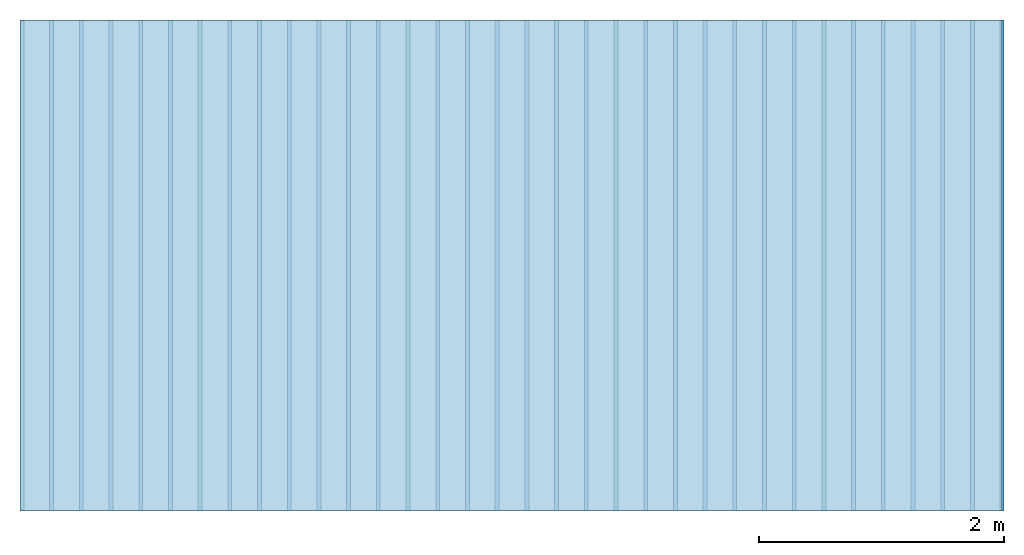
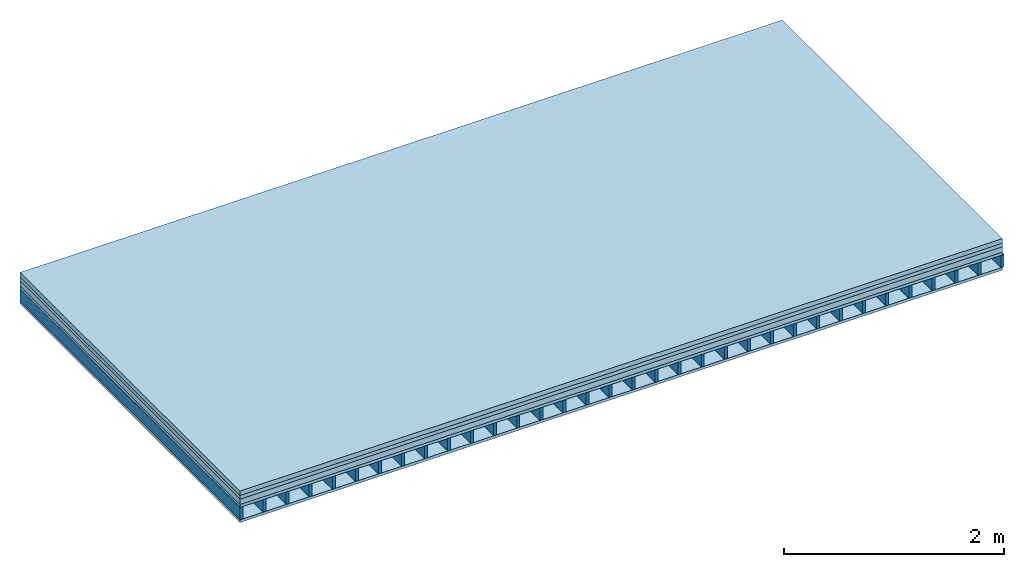
# One storey: 5 plates, 1 member, 1 element without a shape of its own.
"""IFC4 building model written with IfcOpenShell, lengths in metres."""

from ifc_helpers import new_model, si_unit, derived_unit, direction, frame, frame_2d, origin, origin_with_axes, place, context, project, spatial, rectangle, extrude, material, layer, layer_set, type_object, element, aggregate, save


model = new_model("IFC4")

# Units and contexts
plan_context = context("Plan", 3, precision=1e-05, world=origin(), true_north=direction((0.0, 1.0)))
model_context = context("Model", 3, precision=1e-05, world=origin(), true_north=direction((0.0, 1.0)))
ifc_project = project(units=[si_unit("LENGTHUNIT", "METRE"), derived_unit("SOUNDPRESSUREUNIT", [(si_unit("PRESSUREUNIT", "PASCAL", prefix="MICRO"), 0)]), si_unit("ENERGYUNIT", "JOULE", prefix="MEGA"), si_unit("MASSUNIT", "GRAM", prefix="KILO"), derived_unit("THERMALTRANSMITTANCEUNIT", [(si_unit("POWERUNIT", "WATT"), 1), (si_unit("AREAUNIT", "SQUARE_METRE"), -1), (si_unit("THERMODYNAMICTEMPERATUREUNIT", "KELVIN"), -1)]), derived_unit("AREADENSITYUNIT", [(si_unit("MASSUNIT", "GRAM", prefix="KILO"), 1), (si_unit("AREAUNIT", "SQUARE_METRE"), -1)]), derived_unit("USERDEFINED", [(si_unit("ENERGYUNIT", "JOULE", prefix="MEGA"), 1), (si_unit("AREAUNIT", "SQUARE_METRE"), -1)])], contexts=[plan_context, model_context])

# Site, building, storey
site = spatial("IfcSite", under=ifc_project)
building_placement = place(None, origin())
building = spatial("IfcBuilding", under=site, at=building_placement)
storey_placement = place(building_placement, origin())
storey = spatial("IfcBuildingStorey", under=building, at=storey_placement)

# Slab, member, plates
ifc_material_1 = material(Name="Cement screed", Category="04.006")
ifc_layer_1 = layer(ifc_material_1, 0.05, Name="On-material")
ifc_material_2 = material(Name="EP1, 40/35mm")
ifc_layer_2 = layer(ifc_material_2, 0.04, Name="Impact sound insulation")
ifc_material_3 = material(Category="03.011")
ifc_layer_3 = layer(ifc_material_3, 0.06, Name="on Supporting structure")
ifc_material_4 = material(Name="surface element sheathing above")
ifc_layer_4 = layer(ifc_material_4, 0.031, Name="Sub-floor")
ifc_layer_5 = layer(None, 0.138, Name="Supporting structure")
ifc_material_5 = material(Name="surface element sheathing below")
ifc_layer_6 = layer(ifc_material_5, 0.031, Name="Lower layer 1")
ifc_layer_set = layer_set([ifc_layer_1, ifc_layer_2, ifc_layer_3, ifc_layer_4, ifc_layer_5, ifc_layer_6])
slab_type = type_object("IfcSlabType", Name="A0082", PredefinedType="NOTDEFINED", material=ifc_layer_set)
slab_placement = place(None, frame((0.0, 0.0, 0.0), z_axis=(0.0, 0.0, -1.0), x_axis=(1.0, 0.0, 0.0)))
slab = element("IfcSlab", 1, at=slab_placement, inside=storey, type_object=slab_type, material=ifc_layer_set, Name="Slab #1")
ifc_material_6 = material(Name="surface element LFE")
member_placement = place(slab_placement, origin())
member = element("IfcMember", 2, at=member_placement, material=ifc_material_6, Name="Supporting structure", context=plan_context, shape_type="SweptSolid", body=[
    extrude(rectangle(XDim=0.031, YDim=0.138, at=frame_2d((0.0155, 0.069), x_axis=(1.0, 0.0))), frame((0.0, 4.0, 0.181), z_axis=(0.0, -1.0, 0.0), x_axis=(1.0, 0.0, 0.0)), (0.0, 0.0, 1.0), 4.0),
    extrude(rectangle(XDim=0.031, YDim=0.138, at=frame_2d((0.0155, 0.069), x_axis=(1.0, 0.0))), frame((0.242, 4.0, 0.181), z_axis=(0.0, -1.0, 0.0), x_axis=(1.0, 0.0, 0.0)), (0.0, 0.0, 1.0), 4.0),
    extrude(rectangle(XDim=0.031, YDim=0.138, at=frame_2d((0.0155, 0.069), x_axis=(1.0, 0.0))), frame((0.484, 4.0, 0.181), z_axis=(0.0, -1.0, 0.0), x_axis=(1.0, 0.0, 0.0)), (0.0, 0.0, 1.0), 4.0),
    extrude(rectangle(XDim=0.031, YDim=0.138, at=frame_2d((0.0155, 0.069), x_axis=(1.0, 0.0))), frame((0.726, 4.0, 0.181), z_axis=(0.0, -1.0, 0.0), x_axis=(1.0, 0.0, 0.0)), (0.0, 0.0, 1.0), 4.0),
    extrude(rectangle(XDim=0.031, YDim=0.138, at=frame_2d((0.0155, 0.069), x_axis=(1.0, 0.0))), frame((0.968, 4.0, 0.181), z_axis=(0.0, -1.0, 0.0), x_axis=(1.0, 0.0, 0.0)), (0.0, 0.0, 1.0), 4.0),
    extrude(rectangle(XDim=0.031, YDim=0.138, at=frame_2d((0.0155, 0.069), x_axis=(1.0, 0.0))), frame((1.21, 4.0, 0.181), z_axis=(0.0, -1.0, 0.0), x_axis=(1.0, 0.0, 0.0)), (0.0, 0.0, 1.0), 4.0),
    extrude(rectangle(XDim=0.031, YDim=0.138, at=frame_2d((0.0155, 0.069), x_axis=(1.0, 0.0))), frame((1.452, 4.0, 0.181), z_axis=(0.0, -1.0, 0.0), x_axis=(1.0, 0.0, 0.0)), (0.0, 0.0, 1.0), 4.0),
    extrude(rectangle(XDim=0.031, YDim=0.138, at=frame_2d((0.0155, 0.069), x_axis=(1.0, 0.0))), frame((1.694, 4.0, 0.181), z_axis=(0.0, -1.0, 0.0), x_axis=(1.0, 0.0, 0.0)), (0.0, 0.0, 1.0), 4.0),
    extrude(rectangle(XDim=0.031, YDim=0.138, at=frame_2d((0.0155, 0.069), x_axis=(1.0, 0.0))), frame((1.936, 4.0, 0.181), z_axis=(0.0, -1.0, 0.0), x_axis=(1.0, 0.0, 0.0)), (0.0, 0.0, 1.0), 4.0),
    extrude(rectangle(XDim=0.031, YDim=0.138, at=frame_2d((0.0155, 0.069), x_axis=(1.0, 0.0))), frame((2.178, 4.0, 0.181), z_axis=(0.0, -1.0, 0.0), x_axis=(1.0, 0.0, 0.0)), (0.0, 0.0, 1.0), 4.0),
    extrude(rectangle(XDim=0.031, YDim=0.138, at=frame_2d((0.0155, 0.069), x_axis=(1.0, 0.0))), frame((2.42, 4.0, 0.181), z_axis=(0.0, -1.0, 0.0), x_axis=(1.0, 0.0, 0.0)), (0.0, 0.0, 1.0), 4.0),
    extrude(rectangle(XDim=0.031, YDim=0.138, at=frame_2d((0.0155, 0.069), x_axis=(1.0, 0.0))), frame((2.662, 4.0, 0.181), z_axis=(0.0, -1.0, 0.0), x_axis=(1.0, 0.0, 0.0)), (0.0, 0.0, 1.0), 4.0),
    extrude(rectangle(XDim=0.031, YDim=0.138, at=frame_2d((0.0155, 0.069), x_axis=(1.0, 0.0))), frame((2.904, 4.0, 0.181), z_axis=(0.0, -1.0, 0.0), x_axis=(1.0, 0.0, 0.0)), (0.0, 0.0, 1.0), 4.0),
    extrude(rectangle(XDim=0.031, YDim=0.138, at=frame_2d((0.0155, 0.069), x_axis=(1.0, 0.0))), frame((3.146, 4.0, 0.181), z_axis=(0.0, -1.0, 0.0), x_axis=(1.0, 0.0, 0.0)), (0.0, 0.0, 1.0), 4.0),
    extrude(rectangle(XDim=0.031, YDim=0.138, at=frame_2d((0.0155, 0.069), x_axis=(1.0, 0.0))), frame((3.388, 4.0, 0.181), z_axis=(0.0, -1.0, 0.0), x_axis=(1.0, 0.0, 0.0)), (0.0, 0.0, 1.0), 4.0),
    extrude(rectangle(XDim=0.031, YDim=0.138, at=frame_2d((0.0155, 0.069), x_axis=(1.0, 0.0))), frame((3.63, 4.0, 0.181), z_axis=(0.0, -1.0, 0.0), x_axis=(1.0, 0.0, 0.0)), (0.0, 0.0, 1.0), 4.0),
    extrude(rectangle(XDim=0.031, YDim=0.138, at=frame_2d((0.0155, 0.069), x_axis=(1.0, 0.0))), frame((3.872, 4.0, 0.181), z_axis=(0.0, -1.0, 0.0), x_axis=(1.0, 0.0, 0.0)), (0.0, 0.0, 1.0), 4.0),
    extrude(rectangle(XDim=0.031, YDim=0.138, at=frame_2d((0.0155, 0.069), x_axis=(1.0, 0.0))), frame((4.114, 4.0, 0.181), z_axis=(0.0, -1.0, 0.0), x_axis=(1.0, 0.0, 0.0)), (0.0, 0.0, 1.0), 4.0),
    extrude(rectangle(XDim=0.031, YDim=0.138, at=frame_2d((0.0155, 0.069), x_axis=(1.0, 0.0))), frame((4.356, 4.0, 0.181), z_axis=(0.0, -1.0, 0.0), x_axis=(1.0, 0.0, 0.0)), (0.0, 0.0, 1.0), 4.0),
    extrude(rectangle(XDim=0.031, YDim=0.138, at=frame_2d((0.0155, 0.069), x_axis=(1.0, 0.0))), frame((4.598, 4.0, 0.181), z_axis=(0.0, -1.0, 0.0), x_axis=(1.0, 0.0, 0.0)), (0.0, 0.0, 1.0), 4.0),
    extrude(rectangle(XDim=0.031, YDim=0.138, at=frame_2d((0.0155, 0.069), x_axis=(1.0, 0.0))), frame((4.84, 4.0, 0.181), z_axis=(0.0, -1.0, 0.0), x_axis=(1.0, 0.0, 0.0)), (0.0, 0.0, 1.0), 4.0),
    extrude(rectangle(XDim=0.031, YDim=0.138, at=frame_2d((0.0155, 0.069), x_axis=(1.0, 0.0))), frame((5.082, 4.0, 0.181), z_axis=(0.0, -1.0, 0.0), x_axis=(1.0, 0.0, 0.0)), (0.0, 0.0, 1.0), 4.0),
    extrude(rectangle(XDim=0.031, YDim=0.138, at=frame_2d((0.0155, 0.069), x_axis=(1.0, 0.0))), frame((5.324, 4.0, 0.181), z_axis=(0.0, -1.0, 0.0), x_axis=(1.0, 0.0, 0.0)), (0.0, 0.0, 1.0), 4.0),
    extrude(rectangle(XDim=0.031, YDim=0.138, at=frame_2d((0.0155, 0.069), x_axis=(1.0, 0.0))), frame((5.566, 4.0, 0.181), z_axis=(0.0, -1.0, 0.0), x_axis=(1.0, 0.0, 0.0)), (0.0, 0.0, 1.0), 4.0),
    extrude(rectangle(XDim=0.031, YDim=0.138, at=frame_2d((0.0155, 0.069), x_axis=(1.0, 0.0))), frame((5.808, 4.0, 0.181), z_axis=(0.0, -1.0, 0.0), x_axis=(1.0, 0.0, 0.0)), (0.0, 0.0, 1.0), 4.0),
    extrude(rectangle(XDim=0.031, YDim=0.138, at=frame_2d((0.0155, 0.069), x_axis=(1.0, 0.0))), frame((6.05, 4.0, 0.181), z_axis=(0.0, -1.0, 0.0), x_axis=(1.0, 0.0, 0.0)), (0.0, 0.0, 1.0), 4.0),
    extrude(rectangle(XDim=0.031, YDim=0.138, at=frame_2d((0.0155, 0.069), x_axis=(1.0, 0.0))), frame((6.292, 4.0, 0.181), z_axis=(0.0, -1.0, 0.0), x_axis=(1.0, 0.0, 0.0)), (0.0, 0.0, 1.0), 4.0),
    extrude(rectangle(XDim=0.031, YDim=0.138, at=frame_2d((0.0155, 0.069), x_axis=(1.0, 0.0))), frame((6.534, 4.0, 0.181), z_axis=(0.0, -1.0, 0.0), x_axis=(1.0, 0.0, 0.0)), (0.0, 0.0, 1.0), 4.0),
    extrude(rectangle(XDim=0.031, YDim=0.138, at=frame_2d((0.0155, 0.069), x_axis=(1.0, 0.0))), frame((6.776, 4.0, 0.181), z_axis=(0.0, -1.0, 0.0), x_axis=(1.0, 0.0, 0.0)), (0.0, 0.0, 1.0), 4.0),
    extrude(rectangle(XDim=0.031, YDim=0.138, at=frame_2d((0.0155, 0.069), x_axis=(1.0, 0.0))), frame((7.018, 4.0, 0.181), z_axis=(0.0, -1.0, 0.0), x_axis=(1.0, 0.0, 0.0)), (0.0, 0.0, 1.0), 4.0),
    extrude(rectangle(XDim=0.031, YDim=0.138, at=frame_2d((0.0155, 0.069), x_axis=(1.0, 0.0))), frame((7.26, 4.0, 0.181), z_axis=(0.0, -1.0, 0.0), x_axis=(1.0, 0.0, 0.0)), (0.0, 0.0, 1.0), 4.0),
    extrude(rectangle(XDim=0.031, YDim=0.138, at=frame_2d((0.0155, 0.069), x_axis=(1.0, 0.0))), frame((7.502, 4.0, 0.181), z_axis=(0.0, -1.0, 0.0), x_axis=(1.0, 0.0, 0.0)), (0.0, 0.0, 1.0), 4.0),
    extrude(rectangle(XDim=0.031, YDim=0.138, at=frame_2d((0.0155, 0.069), x_axis=(1.0, 0.0))), frame((7.744, 4.0, 0.181), z_axis=(0.0, -1.0, 0.0), x_axis=(1.0, 0.0, 0.0)), (0.0, 0.0, 1.0), 4.0),
    extrude(rectangle(XDim=0.031, YDim=0.138, at=frame_2d((0.0155, 0.069), x_axis=(1.0, 0.0))), frame((7.986, 4.0, 0.181), z_axis=(0.0, -1.0, 0.0), x_axis=(1.0, 0.0, 0.0)), (0.0, 0.0, 1.0), 4.0),
])
plate_1_placement = place(slab_placement, origin())
plate_1 = element("IfcPlate", 3, at=plate_1_placement, material=ifc_material_1, Name="On-material", context=plan_context, shape_type="SweptSolid", body=[
    extrude(rectangle(XDim=8.0, YDim=4.0, at=frame_2d((4.0, 2.0), x_axis=(1.0, 0.0))), origin_with_axes(), (0.0, 0.0, 1.0), 0.05),
])
plate_2_placement = place(slab_placement, origin())
plate_2 = element("IfcPlate", 4, at=plate_2_placement, material=ifc_material_2, Name="Impact sound insulation", context=plan_context, shape_type="SweptSolid", body=[
    extrude(rectangle(XDim=8.0, YDim=4.0, at=frame_2d((4.0, 2.0), x_axis=(1.0, 0.0))), frame((0.0, 0.0, 0.05), z_axis=(0.0, 0.0, 1.0), x_axis=(1.0, 0.0, 0.0)), (0.0, 0.0, 1.0), 0.04),
])
plate_3_placement = place(slab_placement, origin())
plate_3 = element("IfcPlate", 5, at=plate_3_placement, material=ifc_material_3, Name="on Supporting structure", context=plan_context, shape_type="SweptSolid", body=[
    extrude(rectangle(XDim=8.0, YDim=4.0, at=frame_2d((4.0, 2.0), x_axis=(1.0, 0.0))), frame((0.0, 0.0, 0.09), z_axis=(0.0, 0.0, 1.0), x_axis=(1.0, 0.0, 0.0)), (0.0, 0.0, 1.0), 0.06),
])
plate_4_placement = place(slab_placement, origin())
plate_4 = element("IfcPlate", 6, at=plate_4_placement, material=ifc_material_4, Name="Sub-floor", context=plan_context, shape_type="SweptSolid", body=[
    extrude(rectangle(XDim=8.0, YDim=4.0, at=frame_2d((4.0, 2.0), x_axis=(1.0, 0.0))), frame((0.0, 0.0, 0.15), z_axis=(0.0, 0.0, 1.0), x_axis=(1.0, 0.0, 0.0)), (0.0, 0.0, 1.0), 0.031),
])
plate_5_placement = place(slab_placement, origin())
plate_5 = element("IfcPlate", 7, at=plate_5_placement, material=ifc_material_5, Name="Lower layer 1", context=plan_context, shape_type="SweptSolid", body=[
    extrude(rectangle(XDim=8.0, YDim=4.0, at=frame_2d((4.0, 2.0), x_axis=(1.0, 0.0))), frame((0.0, 0.0, 0.319), z_axis=(0.0, 0.0, 1.0), x_axis=(1.0, 0.0, 0.0)), (0.0, 0.0, 1.0), 0.031),
])
aggregate(slab, [plate_1, plate_2, plate_3, plate_4, member, plate_5])

save(model, "model.ifc")
